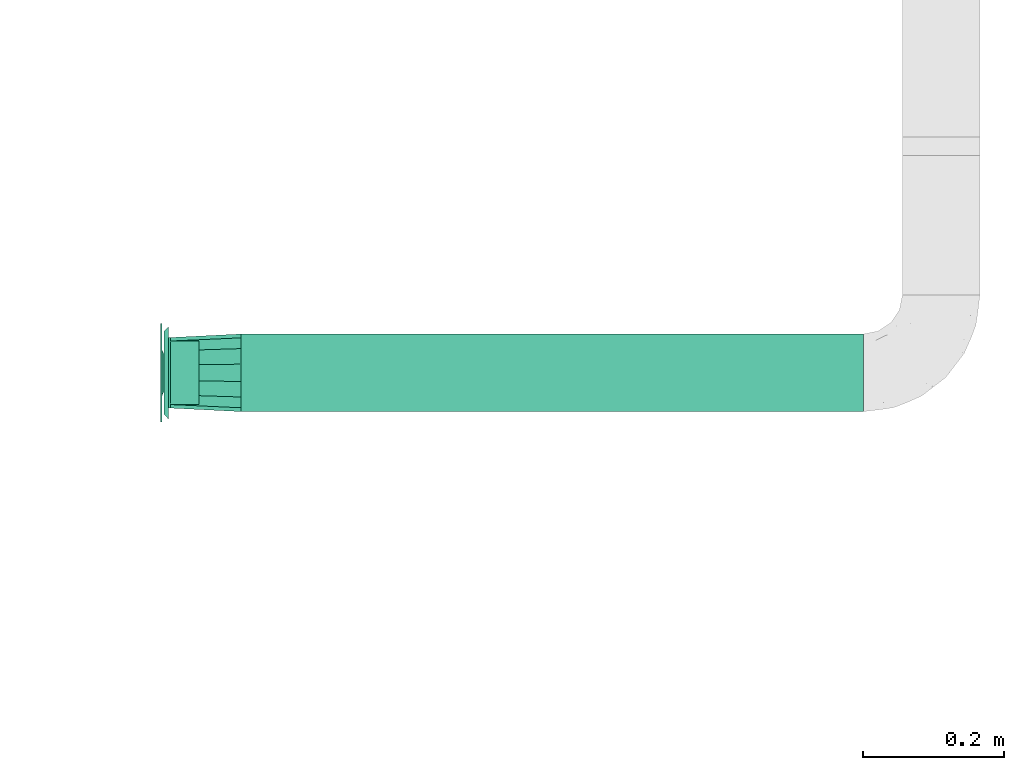
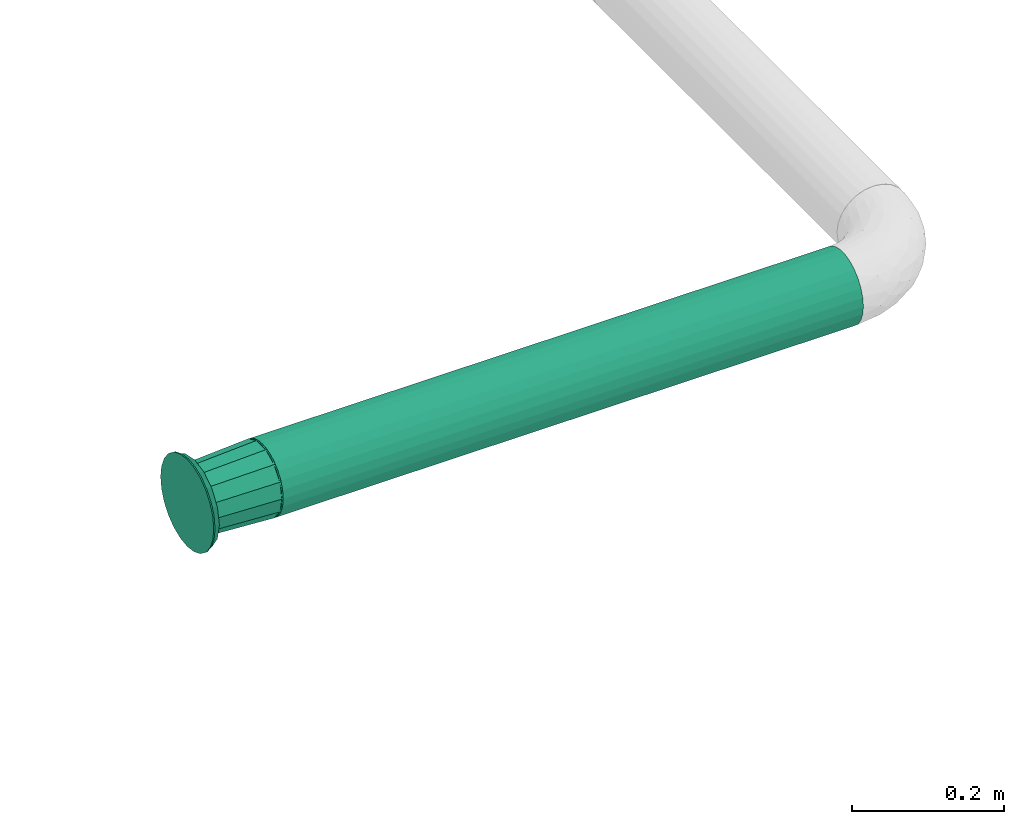
# One storey, part 22 of 103: 1 flow fitting, 1 flow segment, 1 flow terminal.
"""IFC2X3 building model written with IfcOpenShell, lengths in millimetres."""

import ifcopenshell
import ifcopenshell.guid

model = None  # the IFC model being written
_history = None  # IfcOwnerHistory: only IFC2X3 demands one
_inside = {}  # id of a spatial element -> (the spatial element, [elements in it])
_under = {}  # id of a project, library or spatial element -> (it, [spatial elements below it])
_declared = {}  # id of a project -> (the project, [libraries it declares])
_typed = {}  # id of a type object -> (the type object, [elements of that type])
_made_of = {}  # id of a material, layer set ... -> (it, [elements and type objects made of it])


def new_model(schema):
    """Start an empty IFC model of exactly this schema.

    Asked for "IFC4X3", IfcOpenShell would pick the latest addendum, in which some entities
    have other attributes; the version numbers below select the first issue.
    IFC2X3 requires an IfcOwnerHistory on every rooted entity: one is made here for all.
    """
    global model, _history
    if schema == "IFC4X3":
        model = ifcopenshell.file(schema_version=(4, 3, 0, 0))
    else:
        model = ifcopenshell.file(schema=schema)
    _inside.clear()
    _under.clear()
    _declared.clear()
    _typed.clear()
    _made_of.clear()
    _history = None
    if model.schema == "IFC2X3":
        org = make("IfcOrganization", Name="unknown")
        user = make(
            "IfcPersonAndOrganization",
            ThePerson=make("IfcPerson", FamilyName="unknown"),
            TheOrganization=org,
        )
        app = make(
            "IfcApplication",
            ApplicationDeveloper=org,
            Version="unknown",
            ApplicationFullName="unknown",
            ApplicationIdentifier="unknown",
        )
        _history = make(
            "IfcOwnerHistory",
            OwningUser=user,
            OwningApplication=app,
            ChangeAction="ADDED",
            CreationDate=0,
        )
    return model


def make(cls, **values):
    """One entity of the class cls with the attributes given. An attribute that is None is left unset."""
    return model.create_entity(
        cls, **{name: value for name, value in values.items() if value is not None}
    )


def entity(cls, *values):
    """Any entity or typed value of the class cls, its attributes in the order of the schema. None: left unset."""
    e = model.create_entity(cls)
    for i, value in enumerate(values):
        if value is not None:
            e[i] = value
    return e


def rooted(cls, **values):
    """An entity with a GlobalId (a new one), such as an element, a storey or a relation."""
    return make(cls, GlobalId=ifcopenshell.guid.new(), OwnerHistory=_history, **values)


def si_unit(unit_type, name, prefix=None):
    """IfcSIUnit, for example si_unit("LENGTHUNIT", "METRE", prefix="MILLI")."""
    return make("IfcSIUnit", UnitType=unit_type, Prefix=prefix, Name=name)


def converted_unit(unit_type, name, factor, base, dimensions=None, offset=None):
    """IfcConversionBasedUnit, such as the inch: factor (a typed value) times the base unit."""
    return make(
        "IfcConversionBasedUnit"
        if offset is None
        else "IfcConversionBasedUnitWithOffset",
        ConversionOffset=offset,
        Dimensions=None
        if dimensions is None
        else entity("IfcDimensionalExponents", *dimensions),
        UnitType=unit_type,
        Name=name,
        ConversionFactor=make(
            "IfcMeasureWithUnit", ValueComponent=factor, UnitComponent=base
        ),
    )


def derived_unit(unit_type, elements):
    """IfcDerivedUnit: a product of units, each with its exponent."""
    return make(
        "IfcDerivedUnit",
        Elements=[
            make("IfcDerivedUnitElement", Unit=unit, Exponent=power)
            for unit, power in elements
        ],
        UnitType=unit_type,
    )


def assignment(units):
    """IfcUnitAssignment: the units of a project."""
    return None if units is None else make("IfcUnitAssignment", Units=units)


def point(xyz):
    """IfcCartesianPoint."""
    return None if xyz is None else make("IfcCartesianPoint", Coordinates=xyz)


def direction(xyz):
    """IfcDirection."""
    return None if xyz is None else make("IfcDirection", DirectionRatios=xyz)


def frame(location, z_axis=None, x_axis=None):
    """IfcAxis2Placement3D, a coordinate frame: its origin and axes. An axis left out is left unset."""
    return make(
        "IfcAxis2Placement3D",
        Location=point(location),
        Axis=direction(z_axis),
        RefDirection=direction(x_axis),
    )


def frame_2d(location, x_axis=None):
    """IfcAxis2Placement2D, a coordinate frame in the plane: its origin and x axis."""
    return make(
        "IfcAxis2Placement2D", Location=point(location), RefDirection=direction(x_axis)
    )


def origin_with_axes():
    """The frame at (0, 0, 0) with the z axis (0, 0, 1) and the x axis (1, 0, 0) written out."""
    return frame((0.0, 0.0, 0.0), z_axis=(0.0, 0.0, 1.0), x_axis=(1.0, 0.0, 0.0))


def origin_2d_with_axis():
    """The frame at (0, 0) in the plane with the x axis (1, 0) written out."""
    return frame_2d((0.0, 0.0), x_axis=(1.0, 0.0))


def place(relative_to, where):
    """IfcLocalPlacement: puts the frame where relative to a parent placement (None: the world)."""
    return make(
        "IfcLocalPlacement", PlacementRelTo=relative_to, RelativePlacement=where
    )


def context(
    kind, dimensions, precision=None, world=None, true_north=None, identifier=None
):
    """IfcGeometricRepresentationContext, for example the 3D "Model" context."""
    return make(
        "IfcGeometricRepresentationContext",
        ContextIdentifier=identifier,
        ContextType=kind,
        CoordinateSpaceDimension=dimensions,
        Precision=precision,
        WorldCoordinateSystem=world,
        TrueNorth=true_north,
    )


def subcontext(parent, identifier, kind, view, scale=None):
    """IfcGeometricRepresentationSubContext, for example "Body" below "Model"."""
    return make(
        "IfcGeometricRepresentationSubContext",
        ContextIdentifier=identifier,
        ContextType=kind,
        ParentContext=parent,
        TargetScale=scale,
        TargetView=view,
    )


def project(units=None, contexts=None):
    """IfcProject with its units and contexts."""
    return rooted(
        "IfcProject",
        Name="project",
        RepresentationContexts=contexts,
        UnitsInContext=assignment(units),
    )


def spatial(cls, under=None, at=None, **own):
    """A site, building, storey or space (cls), placed at a placement, below another one or the project."""
    s = rooted(cls, ObjectPlacement=at, **own)
    if under is not None:
        _under.setdefault(under.id(), (under, []))[1].append(s)
    return s


def profile(cls, at=None, kind="AREA", **sizes):
    """A parametric profile (cls). Its sizes go by their IFC names, for example OverallWidth=200.0."""
    return make(cls, ProfileType=kind, Position=at, **sizes)


def hollow_circle(**sizes):
    """IfcCircleHollowProfileDef."""
    return profile("IfcCircleHollowProfileDef", **sizes)


def extrude(swept, where, along, depth):
    """IfcExtrudedAreaSolid: the profile swept, set in the frame where, extruded along a direction by depth."""
    return make(
        "IfcExtrudedAreaSolid",
        SweptArea=swept,
        Position=where,
        ExtrudedDirection=direction(along),
        Depth=depth,
    )


def faces_of(points, faces, orient=None, outer=None):
    """IfcFace entities. A face is a list of loops; a loop is a list of indices into points, from 0.

    orient and outer hold one flag for each loop. By default every Orientation is true, the
    first loop of a face is its IfcFaceOuterBound and the others are IfcFaceBound.
    """
    made = []
    for i, loops in enumerate(faces):
        bounds = []
        for j, loop in enumerate(loops):
            is_outer = j == 0 if outer is None else outer[i][j]
            bounds.append(
                make(
                    "IfcFaceOuterBound" if is_outer else "IfcFaceBound",
                    Bound=make("IfcPolyLoop", Polygon=[points[k] for k in loop]),
                    Orientation=True if orient is None else orient[i][j],
                )
            )
        made.append(make("IfcFace", Bounds=bounds))
    return made


def open_shell(faces, orient=None, outer=None):
    """The faces of one IfcOpenShell. surface_model builds it on its shared points."""
    return ("IfcOpenShell", faces, orient, outer)


def surface_model(cls, points, shells):
    """IfcFaceBasedSurfaceModel or IfcShellBasedSurfaceModel (cls): surfaces that need not close."""
    shared = [point(p) for p in points]
    made = [make(c, CfsFaces=faces_of(shared, fs, o, b)) for c, fs, o, b in shells]
    if cls == "IfcFaceBasedSurfaceModel":
        return make(cls, FbsmFaces=made)
    return make(cls, SbsmBoundary=made)


def shape(context_of_items, identifier, shape_type, items):
    """IfcShapeRepresentation: the items that make up one representation, for example the "Body"."""
    return make(
        "IfcShapeRepresentation",
        ContextOfItems=context_of_items,
        RepresentationIdentifier=identifier,
        RepresentationType=shape_type,
        Items=items,
    )


def source(mapping_origin, context_of_items, identifier, shape_type, items):
    """IfcRepresentationMap: a shape defined once, which mapped items show again and again."""
    return make(
        "IfcRepresentationMap",
        MappingOrigin=mapping_origin,
        MappedRepresentation=shape(context_of_items, identifier, shape_type, items),
    )


def transform(
    local_origin,
    x_axis=None,
    y_axis=None,
    z_axis=None,
    scale=None,
    scale2=None,
    scale3=None,
    uniform=True,
):
    """IfcCartesianTransformationOperator3D, or its non-uniform kind. x_axis, y_axis, z_axis: its Axis1, 2, 3."""
    if uniform:
        return make(
            "IfcCartesianTransformationOperator3D",
            Axis1=direction(x_axis),
            Axis2=direction(y_axis),
            LocalOrigin=point(local_origin),
            Scale=scale,
            Axis3=direction(z_axis),
        )
    return make(
        "IfcCartesianTransformationOperator3DnonUniform",
        Axis1=direction(x_axis),
        Axis2=direction(y_axis),
        LocalOrigin=point(local_origin),
        Scale=scale,
        Axis3=direction(z_axis),
        Scale2=scale2,
        Scale3=scale3,
    )


def mapped(mapping_source, mapping_target):
    """IfcMappedItem: shows the shape of a source again, moved by a transform."""
    return make(
        "IfcMappedItem", MappingSource=mapping_source, MappingTarget=mapping_target
    )


def material(Name=None, Category=None):
    """IfcMaterial."""
    return make("IfcMaterial", Name=Name, Category=Category)


def layer(
    of_material, thickness, ventilated=None, Name=None, Category=None, Priority=None
):
    """IfcMaterialLayer: one layer of a wall or slab, of a material (None: an air gap)."""
    return make(
        "IfcMaterialLayer",
        Material=of_material,
        LayerThickness=thickness,
        IsVentilated=ventilated,
        Name=Name,
        Category=Category,
        Priority=Priority,
    )


def layer_set(layers, Name=None):
    """IfcMaterialLayerSet."""
    return make("IfcMaterialLayerSet", MaterialLayers=layers, LayerSetName=Name)


def layer_usage(for_layer_set, set_direction, sense, offset, extent=None):
    """IfcMaterialLayerSetUsage: how a layer set lies in its element."""
    return make(
        "IfcMaterialLayerSetUsage",
        ForLayerSet=for_layer_set,
        LayerSetDirection=set_direction,
        DirectionSense=sense,
        OffsetFromReferenceLine=offset,
        ReferenceExtent=extent,
    )


def made_of(thing, what):
    """Note that an element or type object is made of a material, layer set ...; save() writes the relation."""
    if what is not None:
        _made_of.setdefault(what.id(), (what, []))[1].append(thing)
    return thing


def type_object(cls, material=None, **own):
    """A type object (cls), such as IfcWallType, which elements share."""
    return made_of(rooted(cls, **own), material)


def element(
    cls,
    number,
    at=None,
    inside=None,
    cuts=None,
    type_object=None,
    material=None,
    context=None,
    identifier="Body",
    shape_type=None,
    held_by="IfcProductDefinitionShape",
    body=None,
    shapes=None,
    **own,
):
    """One element of the class cls, such as IfcWall. Its Tag is "e" and its number.

    at: its placement. inside: the storey or other place that contains it. cuts: it is an
    opening in that element (IfcRelVoidsElement). A single representation is given by context,
    identifier, shape_type and body (its items); several are given by shapes. held_by: the class
    of the entity that holds the representations. save() writes the other relations.
    """
    e = rooted(cls, Tag="e%d" % number, ObjectPlacement=at, **own)
    if body is not None:
        shapes = [shape(context, identifier, shape_type, body)]
    if shapes is not None:
        e.Representation = make(held_by, Representations=shapes)
    if inside is not None:
        _inside.setdefault(inside.id(), (inside, []))[1].append(e)
    if cuts is not None:
        rooted(
            "IfcRelVoidsElement", RelatingBuildingElement=cuts, RelatedOpeningElement=e
        )
    if type_object is not None:
        _typed.setdefault(type_object.id(), (type_object, []))[1].append(e)
    return made_of(e, material)


def aggregate(whole, parts):
    """IfcRelAggregates: a whole, such as a stair, and the parts it consists of."""
    return rooted("IfcRelAggregates", RelatingObject=whole, RelatedObjects=parts)


def save(model, path):
    """Write the relations noted so far, then the file.

    IfcRelAggregates (storeys below a building ...), IfcRelContainedInSpatialStructure (elements
    in a storey), IfcRelDefinesByType, IfcRelAssociatesMaterial and IfcRelDeclares: one each for
    every whole, place, type object, material and project.
    """
    for whole, parts in _under.values():
        aggregate(whole, parts)
    for where, things in _inside.values():
        rooted(
            "IfcRelContainedInSpatialStructure",
            RelatedElements=things,
            RelatingStructure=where,
        )
    for kind, things in _typed.values():
        rooted("IfcRelDefinesByType", RelatedObjects=things, RelatingType=kind)
    for what, things in _made_of.values():
        rooted("IfcRelAssociatesMaterial", RelatedObjects=things, RelatingMaterial=what)
    for by, libraries in _declared.values():
        rooted("IfcRelDeclares", RelatingContext=by, RelatedDefinitions=libraries)
    model.write(path)


model = new_model("IFC2X3")

# Units and contexts
model_context = context("Model", 3, precision=1e-05, world=origin_with_axes(), true_north=direction((0.0, 1.0)))
body_context = subcontext(model_context, "Body", "Model", "MODEL_VIEW")
ifc_project = project(units=[si_unit("AREAUNIT", "SQUARE_METRE"), si_unit("VOLUMEUNIT", "CUBIC_METRE", prefix="DECI"), si_unit("TIMEUNIT", "SECOND"), si_unit("THERMODYNAMICTEMPERATUREUNIT", "DEGREE_CELSIUS"), si_unit("PRESSUREUNIT", "PASCAL"), si_unit("MASSUNIT", "GRAM", prefix="KILO"), si_unit("LENGTHUNIT", "METRE", prefix="MILLI"), si_unit("POWERUNIT", "WATT"), si_unit("ELECTRICCURRENTUNIT", "AMPERE"), si_unit("ELECTRICVOLTAGEUNIT", "VOLT"), derived_unit("VOLUMETRICFLOWRATEUNIT", [(si_unit("VOLUMEUNIT", "CUBIC_METRE", prefix="DECI"), 1), (si_unit("TIMEUNIT", "SECOND"), -1)]), derived_unit("LINEARVELOCITYUNIT", [(si_unit("LENGTHUNIT", "METRE"), 1), (si_unit("TIMEUNIT", "SECOND"), -1)]), derived_unit("MASSDENSITYUNIT", [(si_unit("MASSUNIT", "GRAM", prefix="KILO"), 1), (si_unit("VOLUMEUNIT", "CUBIC_METRE"), -1)]), converted_unit("PLANEANGLEUNIT", "DEGREE", entity("IfcRatioMeasure", 0.01745), si_unit("PLANEANGLEUNIT", "RADIAN"), dimensions=[0, 0, 0, 0, 0, 0, 0])], contexts=[model_context])

# Site, building, storey
site_placement = place(None, origin_with_axes())
site = spatial("IfcSite", under=ifc_project, at=site_placement, CompositionType="ELEMENT")
building_placement = place(site_placement, origin_with_axes())
building = spatial("IfcBuilding", under=site, at=building_placement, Name="mc-building", CompositionType="ELEMENT")
storey_placement = place(building_placement, frame((0.0, 0.0, 5900.0), z_axis=(0.0, 0.0, 1.0), x_axis=(1.0, 0.0, 0.0)))
storey = spatial("IfcBuildingStorey", under=building, at=storey_placement, Name="3. Korrus", CompositionType="ELEMENT", Elevation=5900.0)

# Flow fitting
duct_fitting_type = type_object("IfcDuctFittingType", PredefinedType="TRANSITION")
shared_shape_1 = source(origin_with_axes(), body_context, "Body", "SurfaceModel", [
    surface_model("IfcShellBasedSurfaceModel", [(0.0, 12.94095, 48.29629), (0.0, -35.35534, 35.35534), (0.0, 0.0, 50.0), (0.0, 35.35534, 35.35534), (0.0, 25.0, 43.30127), (0.0, 43.30127, 25.0), (0.0, 48.29629, 12.94095), (0.0, -12.94095, 48.29629), (0.0, -25.0, 43.30127), (0.0, -48.29629, 12.94095), (0.0, -43.30127, 25.0), (0.0, -25.0, -43.30127), (0.0, -48.29629, -12.94095), (0.0, -50.0, 0.0), (0.0, 48.29629, -12.94095), (0.0, 12.94095, -48.29629), (0.0, 43.30127, -25.0), (0.0, 35.35534, -35.35534), (0.0, 25.0, -43.30127), (0.0, -35.35534, -35.35534), (0.0, -43.30127, -25.0), (0.0, -12.94095, -48.29629), (0.0, 0.0, -50.0), (0.0, 50.0, 0.0), (100.0, -55.0, 0.0), (100.0, -12.23865, 53.62104), (100.0, -34.29194, 43.00073), (100.0, 49.55329, -23.86361), (100.0, 12.23865, 53.62104), (100.0, 34.29194, 43.00073), (100.0, 55.0, 0.0), (100.0, 49.55329, 23.86361), (100.0, -49.55329, 23.86361), (100.0, 12.23865, -53.62104), (100.0, -49.55329, -23.86361), (100.0, -34.29194, -43.00073), (100.0, 34.29194, -43.00073), (100.0, -12.23865, -53.62104), (0.0, 11.12605, 48.7464), (0.0, -11.12605, 48.7464), (0.0, 31.17449, 39.09157), (0.0, -45.04844, -21.69419), (0.0, -45.04844, 21.69419), (0.0, -31.17449, 39.09157), (0.0, 45.04844, 21.69419), (0.0, 45.04844, -21.69419), (0.0, 31.17449, -39.09157), (0.0, -31.17449, -39.09157), (0.0, -11.12605, -48.7464), (0.0, 11.12605, -48.7464), (0.0, -47.52422, -10.84709), (100.0, -41.92261, -33.43217), (0.0, -38.11147, -30.39288), (100.0, 41.92261, -33.43217), (0.0, 38.11147, -30.39288), (0.0, -21.15027, -43.91899), (100.0, -23.2653, -48.31088), (100.0, -52.32388, -11.72483), (100.0, 0.0, -53.62104), (0.0, 0.0, -48.7464), (100.0, 23.2653, -48.31088), (0.0, 21.15027, -43.91899), (100.0, 52.32388, -11.72483), (0.0, 47.52422, -10.84709), (0.0, 47.52422, 10.84709), (100.0, 41.92261, 33.43217), (0.0, 38.11147, 30.39288), (100.0, -41.92261, 33.43217), (0.0, -38.11147, 30.39288), (0.0, 21.15027, 43.91899), (100.0, 23.2653, 48.31088), (100.0, 52.32388, 11.72483), (100.0, 0.0, 53.62104), (0.0, 0.0, 48.7464), (100.0, -23.2653, 48.31088), (0.0, -21.15027, 43.91899), (100.0, -52.32388, 11.72483), (0.0, -47.52422, 10.84709), (100.0, 27.5, -47.63139), (100.0, 0.0, -55.0), (100.0, 14.23505, -53.12592), (100.0, 38.89087, -38.89087), (100.0, -27.5, -47.63139), (100.0, 47.63139, -27.5), (100.0, 53.12592, -14.23505), (100.0, -14.23505, -53.12592), (100.0, -47.63139, -27.5), (100.0, -38.89087, -38.89087), (100.0, -53.12592, -14.23505), (100.0, 53.12592, 14.23505), (100.0, 47.63139, 27.5), (100.0, 27.5, 47.63139), (100.0, 38.89087, 38.89087), (100.0, 14.23505, 53.12592), (100.0, 0.0, 55.0), (100.0, -47.63139, 27.5), (100.0, -53.12592, 14.23505), (100.0, -27.5, 47.63139), (100.0, -38.89087, 38.89087), (100.0, -14.23505, 53.12592), (98.0, 0.0, 55.0), (98.0, 14.23505, 53.12592), (98.0, 27.5, 47.63139), (98.0, 38.89087, 38.89087), (98.0, 47.63139, 27.5), (98.0, -47.63139, 27.5), (98.0, 53.12592, -14.23505), (98.0, -27.5, 47.63139), (98.0, -14.23505, 53.12592), (98.0, -38.89087, 38.89087), (98.0, -55.0, 0.0), (98.0, -53.12592, 14.23505), (98.0, 53.12592, 14.23505), (98.0, 47.63139, -27.5), (98.0, -27.5, -47.63139), (98.0, 0.0, -55.0), (98.0, 38.89087, -38.89087), (98.0, 27.5, -47.63139), (98.0, 14.23505, -53.12592), (98.0, -47.63139, -27.5), (98.0, -38.89087, -38.89087), (98.0, -53.12592, -14.23505), (98.0, -14.23505, -53.12592), (98.0, 55.0, 0.0), (2.0, 12.94095, -48.29629), (2.0, 25.0, -43.30127), (2.0, 35.35534, -35.35534), (2.0, 43.30127, -25.0), (2.0, 48.29629, -12.94095), (2.0, 0.0, -50.0), (2.0, 50.0, 0.0), (2.0, -25.0, -43.30127), (2.0, -12.94095, -48.29629), (2.0, -35.35534, -35.35534), (2.0, -48.29629, -12.94095), (2.0, -43.30127, -25.0), (2.0, -48.29629, 12.94095), (2.0, 48.29629, 12.94095), (2.0, 43.30127, 25.0), (2.0, 35.35534, 35.35534), (2.0, -35.35534, 35.35534), (2.0, 12.94095, 48.29629), (2.0, 25.0, 43.30127), (2.0, 0.0, 50.0), (2.0, -43.30127, 25.0), (2.0, -50.0, 0.0), (2.0, -12.94095, 48.29629), (2.0, -25.0, 43.30127)], [open_shell([[[0, 1, 2]], [[3, 0, 4]], [[3, 5, 6]], [[0, 3, 1]], [[6, 1, 3]], [[7, 1, 8]], [[7, 2, 1]], [[1, 9, 10]], [[9, 1, 11]], [[12, 13, 9]], [[11, 1, 6]], [[6, 14, 11]], [[15, 14, 16]], [[17, 18, 15]], [[17, 15, 16]], [[11, 14, 15]], [[12, 19, 20]], [[19, 12, 11]], [[15, 21, 11]], [[12, 9, 11]], [[22, 21, 15]], [[14, 6, 23]], [[24, 25, 26]], [[25, 27, 28]], [[29, 28, 27]], [[27, 30, 31]], [[31, 29, 27]], [[24, 26, 32]], [[33, 24, 34]], [[33, 34, 35]], [[36, 27, 33]], [[33, 27, 24]], [[35, 37, 33]], [[24, 27, 25]], [[38, 23, 39]], [[40, 23, 38]], [[41, 42, 43]], [[41, 13, 42]], [[23, 43, 39]], [[40, 44, 23]], [[41, 23, 45]], [[41, 45, 46]], [[47, 41, 48]], [[49, 48, 41]], [[41, 46, 49]], [[23, 41, 43]], [[34, 50, 41]], [[47, 51, 52]], [[45, 27, 53]], [[36, 54, 53]], [[55, 48, 56]], [[34, 57, 50]], [[57, 13, 50]], [[13, 57, 24]], [[55, 35, 47]], [[35, 51, 47]], [[51, 41, 52]], [[58, 59, 49]], [[60, 61, 46]], [[37, 59, 58]], [[62, 63, 23]], [[35, 55, 56]], [[23, 30, 62]], [[53, 54, 45]], [[48, 37, 56]], [[33, 49, 61]], [[49, 33, 58]], [[54, 36, 46]], [[63, 27, 45]], [[34, 41, 51]], [[33, 61, 60]], [[48, 59, 37]], [[27, 63, 62]], [[46, 36, 60]], [[31, 64, 44]], [[40, 65, 66]], [[42, 32, 67]], [[26, 68, 67]], [[69, 38, 70]], [[31, 71, 64]], [[71, 23, 64]], [[23, 71, 30]], [[69, 29, 40]], [[29, 65, 40]], [[65, 44, 66]], [[72, 73, 39]], [[74, 75, 43]], [[28, 73, 72]], [[76, 77, 13]], [[29, 69, 70]], [[13, 24, 76]], [[67, 68, 42]], [[38, 28, 70]], [[25, 39, 75]], [[39, 25, 72]], [[68, 26, 43]], [[77, 32, 42]], [[31, 44, 65]], [[25, 75, 74]], [[38, 73, 28]], [[32, 77, 76]], [[43, 26, 74]], [[78, 79, 80]], [[81, 82, 78]], [[82, 83, 84]], [[81, 83, 82]], [[30, 82, 84]], [[79, 82, 85]], [[79, 78, 82]], [[82, 86, 87]], [[82, 30, 86]], [[24, 88, 86]], [[86, 30, 89]], [[90, 24, 89]], [[91, 90, 92]], [[91, 93, 94]], [[90, 91, 24]], [[94, 95, 91]], [[24, 95, 96]], [[24, 91, 95]], [[94, 97, 98]], [[98, 95, 94]], [[97, 94, 99]], [[89, 24, 86]], [[100, 101, 102]], [[100, 102, 103]], [[100, 104, 105]], [[104, 100, 103]], [[106, 105, 104]], [[100, 107, 108]], [[100, 109, 107]], [[105, 110, 111]], [[109, 100, 105]], [[105, 106, 110]], [[106, 104, 112]], [[106, 113, 110]], [[113, 114, 110]], [[115, 116, 117]], [[113, 116, 115]], [[117, 118, 115]], [[119, 114, 120]], [[121, 110, 119]], [[114, 115, 122]], [[119, 110, 114]], [[115, 114, 113]], [[123, 106, 112]], [[121, 88, 110]], [[119, 86, 121]], [[82, 120, 114]], [[119, 120, 87]], [[85, 114, 122]], [[121, 86, 88]], [[88, 24, 110]], [[85, 82, 114]], [[87, 120, 82]], [[87, 86, 119]], [[79, 85, 122]], [[122, 115, 79]], [[118, 80, 115]], [[117, 78, 118]], [[83, 116, 113]], [[117, 116, 81]], [[84, 113, 106]], [[117, 81, 78]], [[78, 80, 118]], [[30, 84, 106]], [[83, 113, 84]], [[83, 81, 116]], [[123, 30, 106]], [[115, 80, 79]], [[112, 89, 123]], [[104, 90, 112]], [[91, 103, 102]], [[104, 103, 92]], [[93, 102, 101]], [[112, 90, 89]], [[89, 30, 123]], [[93, 91, 102]], [[92, 103, 91]], [[92, 90, 104]], [[94, 93, 101]], [[101, 100, 94]], [[108, 99, 100]], [[107, 97, 108]], [[95, 109, 105]], [[107, 109, 98]], [[96, 105, 111]], [[107, 98, 97]], [[97, 99, 108]], [[24, 96, 111]], [[95, 105, 96]], [[95, 98, 109]], [[110, 24, 111]], [[100, 99, 94]], [[124, 125, 126]], [[124, 126, 127]], [[124, 128, 129]], [[128, 124, 127]], [[129, 128, 130]], [[129, 131, 132]], [[129, 130, 131]], [[133, 134, 135]], [[134, 133, 131]], [[131, 136, 134]], [[131, 130, 137]], [[137, 138, 139]], [[140, 137, 139]], [[140, 139, 141]], [[141, 139, 142]], [[140, 141, 143]], [[136, 140, 144]], [[145, 134, 136]], [[140, 146, 147]], [[131, 140, 136]], [[143, 146, 140]], [[131, 137, 140]], [[12, 134, 13]], [[20, 135, 12]], [[131, 19, 11]], [[20, 19, 133]], [[132, 11, 21]], [[12, 135, 134]], [[134, 145, 13]], [[132, 131, 11]], [[133, 19, 131]], [[133, 135, 20]], [[129, 132, 21]], [[21, 22, 129]], [[15, 124, 22]], [[18, 125, 15]], [[127, 17, 16]], [[18, 17, 126]], [[128, 16, 14]], [[18, 126, 125]], [[125, 124, 15]], [[130, 128, 14]], [[127, 16, 128]], [[127, 126, 17]], [[23, 130, 14]], [[22, 124, 129]], [[6, 137, 23]], [[5, 138, 6]], [[142, 3, 4]], [[5, 3, 139]], [[141, 4, 0]], [[6, 138, 137]], [[137, 130, 23]], [[141, 142, 4]], [[139, 3, 142]], [[139, 138, 5]], [[143, 141, 0]], [[0, 2, 143]], [[7, 146, 2]], [[8, 147, 7]], [[144, 1, 10]], [[8, 1, 140]], [[136, 10, 9]], [[8, 140, 147]], [[147, 146, 7]], [[145, 136, 9]], [[144, 10, 136]], [[144, 140, 1]], [[13, 145, 9]], [[2, 146, 143]]])]),
])
flow_fitting_placement = place(storey_placement, frame((14493.97051, 3436.80698, 2345.0), z_axis=(0.0, 0.0, 1.0), x_axis=(1.0, 0.0, 0.0)))
element("IfcFlowFitting", 1, at=flow_fitting_placement, inside=storey, type_object=duct_fitting_type, context=body_context, shape_type="MappedRepresentation", body=[
    mapped(shared_shape_1, transform((0.0, 0.0, 0.0), scale=1.0)),
])

# Flow terminal
air_terminal_type = type_object("IfcAirTerminalType", Name="100", PredefinedType="NOTDEFINED")
shared_shape_2 = source(origin_with_axes(), body_context, "Body", "SurfaceModel", [
    surface_model("IfcShellBasedSurfaceModel", [(11.2, -70.0, 0.0), (11.2, -67.61481, -18.11733), (11.2, -67.61481, 18.11733), (6.2, -14.64625, -20.15883), (9.2, -22.36867, -22.36867), (6.2, -21.19625, -15.39997), (9.2, 16.375, -28.36233), (6.2, 8.09625, -24.91768), (6.2, 14.64625, -20.15883), (6.2, -8.09625, -24.91768), (9.2, -16.375, -28.36233), (6.2, 21.19625, -15.39997), (9.2, 22.36867, -22.36867), (9.2, -8.1875, -30.55617), (9.2, 8.1875, -30.55617), (9.2, 28.36233, -16.375), (9.2, -28.36233, -16.375), (6.2, 14.64625, 20.15883), (9.2, 22.36867, 22.36867), (6.2, 21.19625, 15.39997), (9.2, -16.375, 28.36233), (6.2, -8.09625, 24.91768), (6.2, -14.64625, 20.15883), (6.2, 8.09625, 24.91768), (9.2, 16.375, 28.36233), (6.2, -21.19625, 15.39997), (9.2, -22.36867, 22.36867), (9.2, 8.1875, 30.55617), (9.2, -8.1875, 30.55617), (9.2, -28.36233, 16.375), (9.2, 28.36233, 16.375), (6.2, -53.11211, -25.57744), (6.2, -36.75472, -46.08897), (6.2, -13.11761, -57.472), (6.2, 13.11761, -57.472), (6.2, 36.75472, -46.08897), (6.2, 53.11211, -25.57744), (0.0, -12.53288, -63.00706), (6.2, 0.0, -57.472), (0.0, -46.3155, -46.3155), (0.0, -35.69063, -53.4148), (0.0, 0.0, -65.5), (6.2, 44.93342, -35.83321), (0.0, 46.3155, -46.3155), (0.0, 35.69063, -53.4148), (6.2, -44.93342, -35.83321), (0.0, 12.53288, -63.00706), (0.0, 25.06576, -60.51411), (6.2, 56.03105, -12.78872), (0.0, 60.51411, -25.06576), (0.0, 63.00706, -12.53288), (0.0, 53.4148, -35.69063), (0.0, -25.06576, -60.51411), (0.0, -63.00706, -12.53288), (0.0, -60.51411, -25.06576), (6.2, -56.03105, -12.78872), (0.0, -53.4148, -35.69063), (6.2, 13.11761, 57.472), (0.0, 12.53288, 63.00706), (6.2, 0.0, 57.472), (6.2, 36.75472, 46.08897), (0.0, 46.3155, 46.3155), (0.0, 35.69063, 53.4148), (0.0, 0.0, 65.5), (6.2, -44.93342, 35.83321), (6.2, -36.75472, 46.08897), (0.0, -46.3155, 46.3155), (0.0, -35.69063, 53.4148), (6.2, 44.93342, 35.83321), (0.0, -12.53288, 63.00706), (0.0, -25.06576, 60.51411), (6.2, -13.11761, 57.472), (6.2, -56.03105, 12.78872), (0.0, -60.51411, 25.06576), (0.0, -63.00706, 12.53288), (0.0, -53.4148, 35.69063), (0.0, 25.06576, 60.51411), (0.0, 63.00706, 12.53288), (0.0, 60.51411, 25.06576), (6.2, 56.03105, 12.78872), (0.0, 53.4148, 35.69063), (-3.1, 43.30127, 25.0), (-3.1, -48.29629, -12.94095), (-3.1, -43.30127, 25.0), (-3.1, 25.0, -43.30127), (-3.1, 48.29629, -12.94095), (-3.1, 35.35534, -35.35534), (-3.1, -35.35534, -35.35534), (-3.1, -25.0, -43.30127), (-43.1, 43.46666, 11.64686), (-3.1, 38.97115, 22.5), (-3.1, 43.46666, 11.64686), (-3.1, 45.0, 0.0), (-43.1, 45.0, 0.0), (-3.1, 31.81981, 31.81981), (-43.1, 38.97115, 22.5), (-43.1, -38.97115, 22.5), (-3.1, -38.97115, 22.5), (-3.1, -31.81981, 31.81981), (-3.1, -43.46666, 11.64686), (-43.1, -43.46666, 11.64686), (-43.1, -45.0, 0.0), (-3.1, -45.0, 0.0), (-43.1, -43.46666, -11.64686), (-3.1, -38.97115, -22.5), (-3.1, -43.46666, -11.64686), (-3.1, -11.64686, -43.46666), (-3.1, -22.5, -38.97115), (-43.1, -22.5, -38.97115), (-3.1, -31.81981, -31.81981), (-43.1, -38.97115, -22.5), (-43.1, 22.5, -38.97115), (-3.1, 22.5, -38.97115), (-3.1, 11.64686, -43.46666), (-43.1, 38.97115, -22.5), (-3.1, 38.97115, -22.5), (-3.1, 31.81981, -31.81981), (-3.1, 43.46666, -11.64686), (-43.1, 43.46666, -11.64686), (11.2, -49.49747, -49.49747), (11.2, -35.0, -60.62178), (11.2, -18.11733, -67.61481), (11.2, 67.61481, 18.11733), (11.2, -60.62178, -35.0), (11.2, 18.11733, -67.61481), (11.2, 35.0, -60.62178), (11.2, 0.0, -70.0), (11.2, 60.62178, -35.0), (11.2, 67.61481, -18.11733), (11.2, 49.49747, -49.49747), (11.2, -49.49747, 49.49747), (11.2, -60.62178, 35.0), (11.2, -35.0, 60.62178), (11.2, -18.11733, 67.61481), (11.2, 0.0, 70.0), (11.2, 60.62178, 35.0), (11.2, 49.49747, 49.49747), (11.2, 70.0, 0.0), (11.2, 35.0, 60.62178), (11.2, 18.11733, 67.61481), (9.2, -49.49747, 49.49747), (9.2, -35.0, 60.62178), (9.2, -18.11733, 67.61481), (9.2, -67.61481, 18.11733), (9.2, -70.0, 0.0), (9.2, -60.62178, 35.0), (9.2, 67.61481, 18.11733), (9.2, 35.0, 60.62178), (9.2, 18.11733, 67.61481), (9.2, 0.0, 70.0), (9.2, 60.62178, 35.0), (9.2, 49.49747, 49.49747), (9.2, -67.61481, -18.11733), (9.2, -49.49747, -49.49747), (9.2, -60.62178, -35.0), (9.2, -18.11733, -67.61481), (9.2, 70.0, 0.0), (9.2, -35.0, -60.62178), (9.2, 0.0, -70.0), (9.2, 60.62178, -35.0), (9.2, 49.49747, -49.49747), (9.2, 67.61481, -18.11733), (9.2, 35.0, -60.62178), (9.2, 18.11733, -67.61481), (9.2, -32.75, 0.0), (9.2, 0.0, 32.75), (9.2, 32.75, 0.0), (9.2, 0.0, -32.75), (6.2, 26.2, 0.0), (6.2, -26.2, 0.0), (9.2, -31.06579, -6.28555), (6.2, -23.69812, -7.69999), (6.2, 23.69812, -7.69999), (9.2, 31.06579, -6.28555), (6.2, 0.0, -24.91768), (9.2, 31.06579, 6.28555), (6.2, 23.69812, 7.69999), (6.2, -23.69812, 7.69999), (9.2, -31.06579, 6.28555), (6.2, 0.0, 24.91768), (6.2, 53.11211, 25.57744), (6.2, 58.95, 0.0), (6.2, -53.11211, 25.57744), (6.2, -58.95, 0.0), (0.0, 65.5, 0.0), (0.0, -65.5, 0.0), (6.2, -24.93616, -51.78048), (6.2, 24.93616, -51.78048), (6.2, 24.93616, 51.78048), (6.2, -24.93616, 51.78048), (-3.1, 0.0, 50.0), (-3.1, 35.35534, 35.35534), (-3.1, -12.94095, 48.29629), (-3.1, -25.0, 43.30127), (-3.1, -35.35534, 35.35534), (-3.1, 25.0, 43.30127), (-3.1, 12.94095, 48.29629), (-3.1, 48.29629, 12.94095), (-3.1, 50.0, 0.0), (-3.1, -50.0, 0.0), (-3.1, -48.29629, 12.94095), (-3.1, -43.30127, -25.0), (-3.1, -12.94095, -48.29629), (-3.1, 0.0, -50.0), (-3.1, 43.30127, -25.0), (-3.1, 12.94095, -48.29629), (0.0, -12.94095, -48.29629), (0.0, 0.0, -50.0), (0.0, -25.0, -43.30127), (0.0, -35.35534, -35.35534), (0.0, -48.29629, -12.94095), (0.0, 25.0, -43.30127), (0.0, -43.30127, -25.0), (0.0, 43.30127, 25.0), (0.0, 12.94095, -48.29629), (0.0, 43.30127, -25.0), (0.0, 48.29629, -12.94095), (0.0, 35.35534, -35.35534), (0.0, 50.0, 0.0), (0.0, -50.0, 0.0), (0.0, -48.29629, 12.94095), (0.0, -43.30127, 25.0), (0.0, -35.35534, 35.35534), (0.0, -12.94095, 48.29629), (0.0, -25.0, 43.30127), (0.0, 35.35534, 35.35534), (0.0, 0.0, 50.0), (0.0, 48.29629, 12.94095), (0.0, 25.0, 43.30127), (0.0, 12.94095, 48.29629), (-43.1, -22.5, 38.97115), (-43.1, -11.64686, 43.46666), (-43.1, 0.0, 45.0), (-43.1, 11.64686, 43.46666), (-43.1, -31.81981, 31.81981), (-43.1, 31.81981, 31.81981), (-43.1, 22.5, 38.97115), (-43.1, -31.81981, -31.81981), (-43.1, 31.81981, -31.81981), (-43.1, -11.64686, -43.46666), (-43.1, 11.64686, -43.46666), (-43.1, 0.0, -45.0), (-3.1, 0.0, -45.0), (-3.1, 0.0, 45.0), (-3.1, -22.5, 38.97115), (-3.1, -11.64686, 43.46666), (-3.1, 11.64686, 43.46666), (-3.1, 22.5, 38.97115)], [open_shell([[[0, 1, 2]], [[3, 4, 5]], [[6, 7, 8]], [[3, 9, 10]], [[4, 3, 10]], [[11, 12, 8]], [[13, 10, 9]], [[7, 6, 14]], [[6, 8, 12]], [[12, 11, 15]], [[16, 5, 4]], [[17, 18, 19]], [[20, 21, 22]], [[17, 23, 24]], [[18, 17, 24]], [[25, 26, 22]], [[27, 24, 23]], [[21, 20, 28]], [[20, 22, 26]], [[26, 25, 29]], [[30, 19, 18]], [[31, 32, 33]], [[34, 35, 36]], [[33, 37, 38]], [[32, 39, 40]], [[41, 38, 37]], [[42, 35, 43]], [[44, 43, 35]], [[39, 32, 45]], [[46, 47, 34]], [[48, 49, 50]], [[38, 46, 34]], [[42, 43, 51]], [[33, 52, 37]], [[53, 54, 55]], [[46, 38, 41]], [[56, 39, 45]], [[57, 58, 59]], [[60, 61, 62]], [[63, 59, 58]], [[64, 65, 66]], [[67, 66, 65]], [[61, 60, 68]], [[69, 70, 71]], [[72, 73, 74]], [[59, 69, 71]], [[64, 66, 75]], [[57, 76, 58]], [[77, 78, 79]], [[69, 59, 63]], [[80, 61, 68]], [[81, 82, 83]], [[84, 85, 86]], [[87, 82, 88]], [[89, 90, 91]], [[91, 92, 93]], [[94, 90, 95]], [[96, 97, 98]], [[99, 97, 100]], [[101, 102, 99]], [[103, 104, 105]], [[105, 102, 101]], [[106, 107, 108]], [[109, 104, 110]], [[111, 112, 113]], [[114, 115, 116]], [[117, 115, 118]], [[93, 92, 117]], [[119, 120, 121]], [[1, 119, 121]], [[122, 1, 121]], [[123, 119, 1]], [[124, 122, 121]], [[125, 122, 124]], [[121, 126, 124]], [[127, 128, 129]], [[129, 128, 122]], [[129, 122, 125]], [[130, 131, 2]], [[132, 130, 2]], [[122, 133, 2]], [[132, 2, 133]], [[134, 133, 122]], [[135, 136, 122]], [[122, 128, 137]], [[136, 138, 122]], [[139, 122, 138]], [[122, 139, 134]], [[2, 1, 122]], [[140, 141, 142]], [[143, 140, 142]], [[142, 144, 143]], [[145, 140, 143]], [[146, 144, 142]], [[147, 146, 148]], [[149, 148, 146]], [[150, 146, 151]], [[147, 151, 146]], [[146, 142, 149]], [[146, 152, 144]], [[153, 154, 152]], [[155, 153, 152]], [[146, 156, 155]], [[157, 153, 155]], [[158, 155, 156]], [[159, 160, 161]], [[156, 161, 160]], [[160, 162, 156]], [[163, 156, 162]], [[163, 158, 156]], [[152, 146, 155]], [[156, 128, 161]], [[161, 127, 159]], [[162, 160, 125]], [[129, 160, 159]], [[163, 162, 124]], [[128, 127, 161]], [[156, 137, 128]], [[162, 125, 124]], [[125, 160, 129]], [[159, 127, 129]], [[163, 124, 126]], [[126, 158, 163]], [[158, 121, 155]], [[155, 120, 157]], [[154, 153, 123]], [[119, 153, 157]], [[152, 154, 1]], [[120, 119, 157]], [[155, 121, 120]], [[152, 1, 0]], [[1, 154, 123]], [[153, 119, 123]], [[152, 0, 144]], [[126, 121, 158]], [[144, 2, 143]], [[143, 131, 145]], [[141, 140, 132]], [[130, 140, 145]], [[142, 141, 133]], [[2, 131, 143]], [[144, 0, 2]], [[141, 132, 133]], [[132, 140, 130]], [[145, 131, 130]], [[142, 133, 134]], [[134, 149, 142]], [[149, 139, 148]], [[148, 138, 147]], [[150, 151, 135]], [[136, 151, 147]], [[146, 150, 122]], [[138, 136, 147]], [[148, 139, 138]], [[146, 122, 137]], [[122, 150, 135]], [[151, 136, 135]], [[146, 137, 156]], [[134, 139, 149]], [[30, 24, 164]], [[24, 20, 164]], [[165, 20, 24]], [[164, 20, 29]], [[166, 30, 16]], [[16, 6, 166]], [[167, 6, 10]], [[30, 164, 16]], [[10, 6, 16]], [[6, 15, 166]], [[21, 19, 11]], [[23, 19, 21]], [[11, 19, 168]], [[7, 25, 21]], [[7, 5, 169]], [[21, 11, 7]], [[9, 5, 7]], [[169, 25, 7]], [[170, 164, 169]], [[170, 171, 16]], [[11, 172, 15]], [[172, 168, 173]], [[174, 13, 9]], [[166, 173, 168]], [[172, 173, 15]], [[169, 171, 170]], [[5, 16, 171]], [[167, 174, 14]], [[174, 167, 13]], [[14, 174, 7]], [[175, 166, 168]], [[175, 176, 30]], [[25, 177, 29]], [[177, 169, 178]], [[179, 27, 23]], [[164, 178, 169]], [[177, 178, 29]], [[168, 176, 175]], [[19, 30, 176]], [[165, 179, 28]], [[179, 165, 27]], [[28, 179, 21]], [[180, 60, 57]], [[181, 180, 65]], [[65, 57, 71]], [[180, 57, 65]], [[65, 182, 181]], [[182, 36, 181]], [[183, 34, 36]], [[31, 34, 183]], [[31, 33, 34]], [[182, 183, 36]], [[70, 63, 49]], [[70, 73, 66]], [[49, 63, 184]], [[78, 76, 61]], [[76, 78, 184]], [[184, 63, 76]], [[73, 70, 49]], [[39, 54, 185]], [[41, 39, 185]], [[52, 39, 41]], [[43, 185, 49]], [[185, 43, 47]], [[185, 47, 41]], [[73, 49, 185]], [[55, 54, 31]], [[31, 54, 56]], [[52, 186, 40]], [[53, 55, 183]], [[56, 45, 31]], [[185, 53, 183]], [[32, 40, 186]], [[33, 186, 52]], [[44, 35, 187]], [[49, 36, 51]], [[34, 47, 187]], [[42, 51, 36]], [[187, 47, 44]], [[49, 48, 36]], [[48, 50, 181]], [[184, 181, 50]], [[79, 78, 180]], [[180, 78, 80]], [[76, 188, 62]], [[77, 79, 181]], [[80, 68, 180]], [[184, 77, 181]], [[60, 62, 188]], [[57, 188, 76]], [[67, 65, 189]], [[73, 182, 75]], [[71, 70, 189]], [[64, 75, 182]], [[189, 70, 67]], [[73, 72, 182]], [[72, 74, 183]], [[185, 183, 74]], [[190, 191, 192]], [[193, 192, 194]], [[83, 192, 81]], [[194, 192, 83]], [[195, 191, 196]], [[191, 190, 196]], [[197, 198, 81]], [[81, 192, 191]], [[198, 84, 81]], [[199, 200, 83]], [[81, 88, 82]], [[201, 82, 87]], [[88, 81, 202]], [[81, 203, 202]], [[204, 86, 85]], [[205, 203, 84]], [[84, 198, 85]], [[81, 84, 203]], [[199, 83, 82]], [[206, 207, 208]], [[209, 208, 210]], [[210, 208, 211]], [[212, 209, 210]], [[210, 211, 213]], [[214, 211, 207]], [[211, 208, 207]], [[215, 216, 217]], [[211, 217, 216]], [[216, 218, 211]], [[219, 210, 220]], [[221, 210, 213]], [[222, 221, 223]], [[213, 223, 221]], [[224, 222, 223]], [[223, 225, 226]], [[227, 213, 218]], [[218, 213, 211]], [[228, 229, 225]], [[223, 213, 225]], [[226, 225, 229]], [[221, 220, 210]], [[199, 220, 200]], [[200, 221, 83]], [[193, 194, 224]], [[222, 194, 83]], [[192, 193, 223]], [[220, 221, 200]], [[199, 219, 220]], [[193, 224, 223]], [[224, 194, 222]], [[83, 221, 222]], [[192, 223, 226]], [[226, 190, 192]], [[190, 229, 196]], [[196, 228, 195]], [[81, 191, 213]], [[225, 191, 195]], [[197, 81, 227]], [[228, 225, 195]], [[196, 229, 228]], [[197, 227, 218]], [[227, 81, 213]], [[191, 225, 213]], [[197, 218, 198]], [[226, 229, 190]], [[198, 216, 85]], [[85, 215, 204]], [[84, 86, 211]], [[217, 86, 204]], [[205, 84, 214]], [[216, 215, 85]], [[198, 218, 216]], [[84, 211, 214]], [[211, 86, 217]], [[204, 215, 217]], [[205, 214, 207]], [[207, 203, 205]], [[203, 206, 202]], [[202, 208, 88]], [[201, 87, 212]], [[209, 87, 88]], [[82, 201, 210]], [[208, 209, 88]], [[202, 206, 208]], [[82, 210, 219]], [[210, 201, 212]], [[87, 209, 212]], [[82, 219, 199]], [[207, 206, 203]], [[230, 231, 232]], [[230, 232, 233]], [[230, 100, 96]], [[234, 230, 96]], [[100, 230, 233]], [[235, 89, 236]], [[100, 233, 236]], [[95, 89, 235]], [[118, 89, 93]], [[118, 236, 89]], [[118, 100, 236]], [[110, 103, 101]], [[237, 110, 101]], [[238, 108, 101]], [[237, 101, 108]], [[239, 108, 238]], [[114, 238, 118]], [[238, 101, 118]], [[240, 241, 111]], [[238, 111, 241]], [[238, 241, 239]], [[100, 118, 101]], [[106, 242, 107]], [[107, 112, 109]], [[102, 105, 104]], [[112, 104, 109]], [[92, 104, 117]], [[113, 112, 242]], [[112, 107, 242]], [[115, 117, 116]], [[112, 116, 117]], [[112, 117, 104]], [[92, 102, 104]], [[97, 99, 243]], [[98, 97, 244]], [[243, 245, 244]], [[97, 243, 244]], [[246, 243, 99]], [[90, 94, 91]], [[92, 91, 247]], [[94, 247, 91]], [[247, 99, 92]], [[247, 246, 99]], [[102, 92, 99]], [[101, 99, 100]], [[100, 97, 96]], [[230, 234, 244]], [[98, 234, 96]], [[231, 230, 245]], [[245, 230, 244]], [[244, 234, 98]], [[245, 243, 231]], [[243, 232, 231]], [[236, 233, 246]], [[236, 247, 235]], [[89, 95, 90]], [[94, 95, 235]], [[93, 89, 91]], [[232, 246, 233]], [[246, 247, 236]], [[243, 246, 232]], [[247, 94, 235]], [[93, 117, 118]], [[118, 115, 114]], [[111, 238, 112]], [[116, 238, 114]], [[240, 111, 113]], [[112, 238, 116]], [[240, 113, 242]], [[242, 241, 240]], [[108, 239, 106]], [[108, 107, 237]], [[103, 110, 104]], [[109, 110, 237]], [[101, 103, 105]], [[241, 106, 239]], [[242, 106, 241]], [[107, 109, 237]]])]),
])
flow_terminal_placement = place(storey_placement, frame((14490.87051, 3436.80698, 2345.0), z_axis=(0.0, 0.0, 1.0), x_axis=(-1.0, 0.0, 0.0)))
element("IfcFlowTerminal", 2, at=flow_terminal_placement, inside=storey, type_object=air_terminal_type, Name="100", context=body_context, shape_type="MappedRepresentation", body=[
    mapped(shared_shape_2, transform((0.0, 0.0, 0.0), scale=1.0)),
])

# Flow segment
ifc_material = material(Name="FZ1")
ifc_layer = layer(ifc_material, 0.0)
ifc_layer_set = layer_set([ifc_layer], Name="FZ1")
ifc_layer_usage = layer_usage(ifc_layer_set, "AXIS1", "POSITIVE", 0.0)
duct_segment_type = type_object("IfcDuctSegmentType", Name="Safe", PredefinedType="RIGIDSEGMENT")
shared_shape_3 = source(origin_with_axes(), body_context, "Body", "SweptSolid", [
    extrude(hollow_circle(Radius=55.0, WallThickness=2.0, at=origin_2d_with_axis()), frame((0.0, 0.0, 0.0), z_axis=(1.0, 0.0, 0.0), x_axis=(0.0, 1.0, 0.0)), (0.0, 0.0, 1.0), 881.8),
])
flow_segment_placement = place(storey_placement, frame((14593.97051, 3436.80698, 2345.0), z_axis=(0.0, 0.0, 1.0), x_axis=(1.0, 0.0, 0.0)))
element("IfcFlowSegment", 3, at=flow_segment_placement, inside=storey, type_object=duct_segment_type, material=ifc_layer_usage, Name="Safe", context=body_context, shape_type="MappedRepresentation", body=[
    mapped(shared_shape_3, transform((0.0, 0.0, 0.0), scale=1.0)),
])

save(model, "model.ifc")
